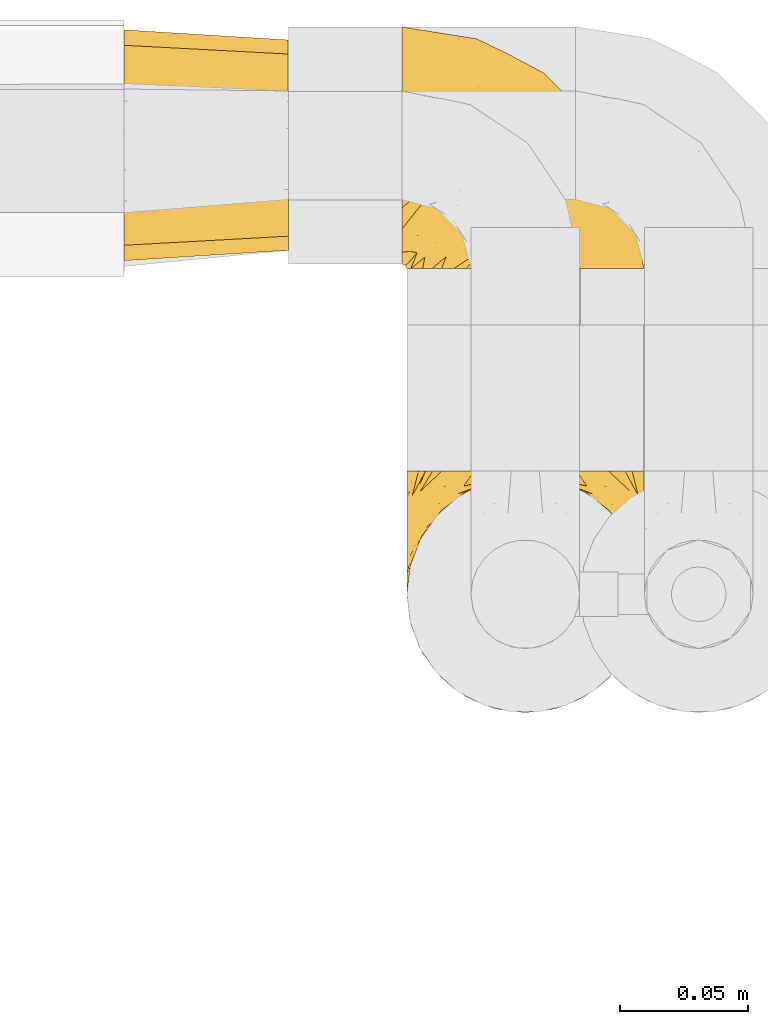
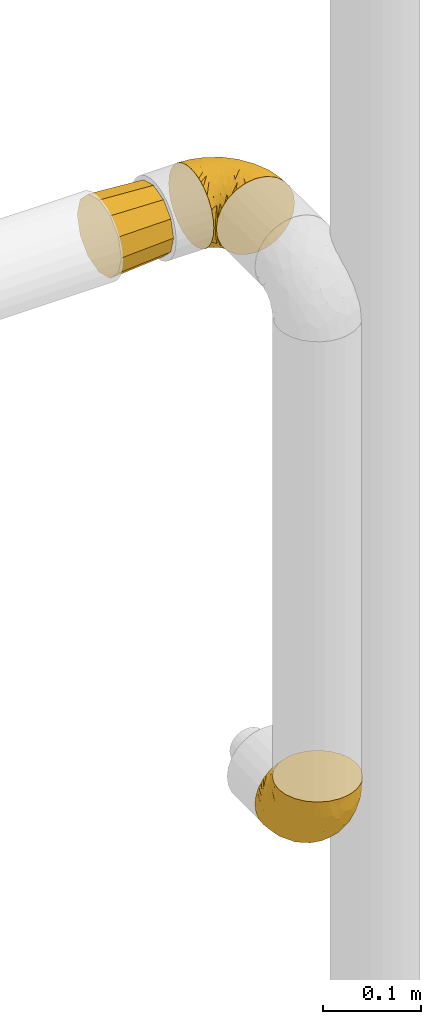
# One storey, part 317 of 827: 3 coverings.
"""IFC2X3 building model written with IfcOpenShell, lengths in millimetres."""

from ifc_helpers import new_model, entity, si_unit, converted_unit, derived_unit, direction, frame, origin, place, context, subcontext, project, spatial, faceted_brep, element, save


model = new_model("IFC2X3")

# Units and contexts
model_context = context("Model", 3, precision=0.01, world=origin(), true_north=direction((6.12303176911189e-17, 1.0)))
body_context = subcontext(model_context, "Body", "Model", "MODEL_VIEW")
ifc_project = project(units=[si_unit("LENGTHUNIT", "METRE", prefix="MILLI"), si_unit("AREAUNIT", "SQUARE_METRE"), si_unit("VOLUMEUNIT", "CUBIC_METRE"), converted_unit("PLANEANGLEUNIT", "DEGREE", entity("IfcRatioMeasure", 0.0174532925199433), si_unit("PLANEANGLEUNIT", "RADIAN"), dimensions=[0, 0, 0, 0, 0, 0, 0]), si_unit("MASSUNIT", "GRAM", prefix="KILO"), derived_unit("MASSDENSITYUNIT", [(si_unit("MASSUNIT", "GRAM", prefix="KILO"), 1), (si_unit("LENGTHUNIT", "METRE"), -3)]), derived_unit("MOMENTOFINERTIAUNIT", [(si_unit("LENGTHUNIT", "METRE"), 4)]), si_unit("TIMEUNIT", "SECOND"), si_unit("FREQUENCYUNIT", "HERTZ"), si_unit("THERMODYNAMICTEMPERATUREUNIT", "DEGREE_CELSIUS"), derived_unit("THERMALTRANSMITTANCEUNIT", [(si_unit("MASSUNIT", "GRAM", prefix="KILO"), 1), (si_unit("THERMODYNAMICTEMPERATUREUNIT", "KELVIN"), -1), (si_unit("TIMEUNIT", "SECOND"), -3)]), derived_unit("VOLUMETRICFLOWRATEUNIT", [(si_unit("LENGTHUNIT", "METRE"), 3), (si_unit("TIMEUNIT", "SECOND"), -1)]), derived_unit("MASSFLOWRATEUNIT", [(si_unit("MASSUNIT", "GRAM", prefix="KILO"), 1), (si_unit("TIMEUNIT", "SECOND"), -1)]), derived_unit("ROTATIONALFREQUENCYUNIT", [(si_unit("TIMEUNIT", "SECOND"), -1)]), si_unit("ELECTRICCURRENTUNIT", "AMPERE"), si_unit("ELECTRICVOLTAGEUNIT", "VOLT"), si_unit("POWERUNIT", "WATT"), si_unit("FORCEUNIT", "NEWTON", prefix="KILO"), si_unit("ILLUMINANCEUNIT", "LUX"), si_unit("LUMINOUSFLUXUNIT", "LUMEN"), si_unit("LUMINOUSINTENSITYUNIT", "CANDELA"), derived_unit("USERDEFINED", [(si_unit("MASSUNIT", "GRAM", prefix="KILO"), -1), (si_unit("LENGTHUNIT", "METRE"), -2), (si_unit("TIMEUNIT", "SECOND"), 3), (si_unit("LUMINOUSFLUXUNIT", "LUMEN"), 1)]), derived_unit("LINEARVELOCITYUNIT", [(si_unit("LENGTHUNIT", "METRE"), 1), (si_unit("TIMEUNIT", "SECOND"), -1)]), si_unit("PRESSUREUNIT", "PASCAL"), derived_unit("USERDEFINED", [(si_unit("LENGTHUNIT", "METRE"), -2), (si_unit("MASSUNIT", "GRAM", prefix="KILO"), 1), (si_unit("TIMEUNIT", "SECOND"), -2)]), derived_unit("LINEARFORCEUNIT", [(si_unit("MASSUNIT", "GRAM", prefix="KILO"), 1), (si_unit("LENGTHUNIT", "METRE"), 1), (si_unit("TIMEUNIT", "SECOND"), -2), (si_unit("LENGTHUNIT", "METRE"), -1)]), derived_unit("PLANARFORCEUNIT", [(si_unit("MASSUNIT", "GRAM", prefix="KILO"), 1), (si_unit("LENGTHUNIT", "METRE"), 1), (si_unit("TIMEUNIT", "SECOND"), -2), (si_unit("LENGTHUNIT", "METRE"), -2)])], contexts=[model_context])

# Site, building, storey
site_placement = place(None, origin())
site = spatial("IfcSite", under=ifc_project, at=site_placement, CompositionType="ELEMENT")
building_placement = place(site_placement, origin())
building = spatial("IfcBuilding", under=site, at=building_placement, CompositionType="ELEMENT")
storey_placement = place(building_placement, frame((0.0, 0.0, 28200.0)))
storey = spatial("IfcBuildingStorey", under=building, at=storey_placement, Name="08", CompositionType="ELEMENT", Elevation=28200.0)

# Coverings
covering_1_placement = place(storey_placement, frame((30526.79, 19295.64, 1082.65)))
element("IfcCovering", 1, at=covering_1_placement, inside=storey, Name=":ADSK_", ObjectType=":ADSK_", PredefinedType="INSULATION", context=body_context, shape_type="Brep", body=[
    faceted_brep([(83.91, 95.8, 18.98), (76.59, 95.8, 11.67), (67.83, 95.8, 6.17), (58.07, 95.8, 2.75), (47.8, 95.8, 1.6), (37.51, 95.8, 2.75), (27.74, 95.8, 6.17), (18.98, 95.8, 11.68), (11.67, 95.8, 19.0), (6.17, 95.8, 27.76), (2.75, 95.8, 37.52), (1.6, 95.8, 47.8), (2.06, 95.8, 51.94), (2.41, 95.8, 55.01), (2.75, 95.8, 58.08), (4.46, 95.8, 62.96), (6.17, 95.8, 67.85), (8.93, 95.8, 72.23), (11.68, 95.8, 76.61), (15.34, 95.8, 80.26), (19.0, 95.8, 83.92), (27.76, 95.8, 89.42), (32.64, 95.8, 91.13), (37.52, 95.8, 92.84), (47.8, 95.8, 94.0), (58.08, 95.8, 92.84), (62.96, 95.8, 91.13), (67.85, 95.8, 89.42), (76.61, 95.8, 83.91), (80.26, 95.8, 80.25), (83.92, 95.8, 76.59), (86.67, 95.8, 72.21), (89.42, 95.8, 67.83), (91.13, 95.8, 62.95), (92.84, 95.8, 58.07), (93.18, 95.8, 55.0), (93.53, 95.8, 51.94), (94.0, 95.8, 47.8), (92.84, 95.8, 37.51), (89.42, 95.8, 27.74), (47.8, 94.0, 95.8), (35.84, 92.42, 95.8), (24.7, 87.81, 95.8), (19.91, 84.13, 95.8), (15.13, 80.46, 95.8), (11.46, 75.68, 95.8), (7.78, 70.9, 95.8), (5.48, 65.32, 95.8), (3.17, 59.75, 95.8), (2.69, 56.14, 95.8), (2.42, 54.06, 95.8), (2.14, 51.97, 95.8), (1.6, 47.8, 95.8), (3.17, 35.84, 95.8), (7.78, 24.7, 95.8), (15.13, 15.13, 95.8), (24.7, 7.78, 95.8), (35.84, 3.17, 95.8), (47.8, 1.6, 95.8), (59.75, 3.17, 95.8), (70.9, 7.78, 95.8), (80.46, 15.13, 95.8), (87.81, 24.7, 95.8), (92.42, 35.84, 95.8), (94.0, 47.8, 95.8), (93.45, 51.97, 95.8), (92.9, 56.14, 95.8), (92.42, 59.75, 95.8), (90.11, 65.32, 95.8), (87.81, 70.9, 95.8), (84.13, 75.68, 95.8), (80.46, 80.46, 95.8), (75.68, 84.13, 95.8), (70.9, 87.81, 95.8), (59.75, 92.42, 95.8), (71.98, 15.84, 60.58), (63.6, 6.99, 74.11), (59.72, 14.39, 51.59), (47.8, 6.21, 66.69), (55.16, 4.26, 76.19), (47.8, 3.39, 84.43), (63.76, 31.2, 31.2), (72.22, 26.47, 42.88), (74.18, 11.44, 79.41), (92.52, 47.66, 60.7), (94.0, 61.85, 61.85), (94.0, 59.25, 65.75), (94.0, 56.65, 69.64), (94.0, 54.05, 73.53), (94.0, 51.45, 77.43), (82.14, 19.8, 74.59), (80.34, 26.22, 54.72), (87.52, 31.58, 64.18), (79.59, 38.36, 37.94), (78.25, 51.54, 25.89), (85.01, 51.6, 34.73), (90.25, 55.97, 42.89), (93.2, 62.88, 49.83), (87.23, 41.35, 48.58), (85.55, 82.24, 22.41), (93.0, 40.88, 78.69), (89.31, 29.0, 81.64), (61.31, 74.06, 6.22), (56.86, 54.53, 12.11), (68.34, 57.98, 14.81), (65.71, 43.81, 21.61), (56.99, 38.22, 22.41), (72.15, 38.33, 30.12), (70.34, 74.76, 10.01), (78.36, 76.85, 15.36), (47.8, 84.43, 3.39), (47.8, 40.43, 19.59), (47.8, 30.01, 30.01), (93.06, 78.67, 41.19), (94.0, 92.06, 48.54), (94.0, 88.32, 49.28), (94.0, 85.6, 49.82), (94.0, 82.88, 50.37), (94.0, 80.15, 50.91), (94.0, 77.43, 51.45), (89.88, 76.36, 31.61), (94.0, 50.91, 80.15), (94.0, 50.37, 82.88), (94.0, 49.82, 85.6), (94.0, 49.28, 88.32), (94.0, 48.91, 90.19), (94.0, 48.54, 92.06), (47.8, 66.69, 6.21), (94.0, 73.53, 54.05), (94.0, 69.64, 56.65), (94.0, 65.75, 59.25), (83.7, 66.13, 24.66), (47.8, 19.59, 40.43), (55.9, 24.64, 35.17), (47.8, 53.56, 12.9), (47.8, 12.9, 53.56), (81.75, 82.81, 85.34), (86.43, 81.22, 78.44), (79.8, 86.57, 84.37), (69.84, 92.75, 89.05), (79.5, 89.68, 82.76), (88.08, 72.26, 86.31), (91.6, 64.73, 83.73), (92.93, 62.45, 77.31), (92.43, 60.63, 87.78), (93.24, 56.91, 87.91), (93.36, 58.14, 81.29), (57.25, 93.7, 93.97), (89.41, 83.4, 70.76), (92.89, 75.54, 63.67), (92.66, 79.46, 62.62), (79.58, 82.28, 90.64), (86.51, 76.25, 84.08), (83.91, 90.18, 77.45), (88.76, 87.92, 70.34), (90.94, 65.12, 88.72), (91.94, 71.71, 71.28), (91.98, 75.21, 68.09), (82.79, 78.6, 91.07), (93.16, 87.27, 57.47), (73.94, 86.94, 91.35), (91.89, 86.1, 62.99), (47.8, 94.52, 94.52), (92.22, 66.23, 76.47), (86.29, 84.69, 76.28), (88.56, 91.08, 69.96), (87.72, 71.77, 89.86), (88.33, 76.21, 78.94), (92.18, 68.59, 73.51), (71.78, 89.94, 89.62), (9.09, 76.25, 84.09), (7.51, 72.26, 86.3), (12.8, 78.6, 91.06), (1.6, 48.54, 92.06), (1.6, 50.37, 82.88), (1.6, 49.82, 85.6), (1.6, 49.28, 88.32), (38.35, 93.7, 93.97), (23.84, 89.95, 89.63), (1.6, 82.88, 50.37), (1.6, 85.6, 49.82), (1.6, 92.06, 48.54), (1.6, 88.32, 49.28), (16.1, 89.68, 82.77), (6.84, 87.92, 70.36), (2.66, 62.45, 77.31), (3.37, 66.24, 76.47), (1.6, 56.65, 69.64), (1.6, 59.25, 65.75), (3.16, 60.63, 87.78), (2.35, 56.91, 87.91), (25.77, 92.76, 89.06), (16.02, 82.28, 90.65), (13.85, 82.81, 85.35), (1.6, 54.05, 73.53), (1.6, 51.45, 77.43), (2.23, 58.14, 81.29), (11.69, 90.18, 77.46), (9.31, 84.7, 76.29), (2.43, 87.25, 57.47), (2.71, 75.58, 63.71), (3.61, 75.2, 68.11), (6.18, 83.39, 70.77), (3.66, 71.7, 71.31), (9.17, 81.22, 78.46), (6.77, 90.73, 69.52), (2.93, 79.47, 62.64), (21.66, 86.94, 91.35), (1.6, 65.75, 59.25), (16.09, 86.75, 84.6), (3.7, 86.08, 62.98), (1.6, 77.43, 51.45), (1.6, 73.53, 54.05), (1.6, 69.64, 56.65), (3.99, 64.73, 83.73), (1.6, 50.91, 80.15), (4.65, 65.12, 88.72), (1.6, 61.85, 61.85), (3.43, 68.62, 73.56), (7.27, 76.22, 78.96), (9.46, 74.03, 91.36), (1.6, 80.15, 50.91), (2.4, 49.81, 62.87), (40.43, 4.26, 76.19), (13.57, 19.95, 73.57), (11.3, 30.61, 56.07), (18.65, 25.71, 49.77), (27.26, 22.43, 44.73), (23.61, 15.85, 60.58), (3.07, 60.69, 47.64), (2.69, 40.49, 78.32), (35.87, 14.39, 51.59), (31.99, 6.99, 74.11), (6.71, 29.56, 76.04), (21.41, 11.45, 79.41), (27.24, 57.98, 14.82), (34.26, 74.06, 6.22), (38.73, 54.52, 12.12), (26.97, 43.47, 23.51), (31.83, 31.2, 31.2), (23.4, 33.27, 34.96), (6.91, 64.26, 33.86), (3.4, 74.29, 38.94), (5.84, 80.41, 30.23), (35.73, 41.67, 20.67), (39.69, 24.64, 35.17), (17.6, 73.62, 15.85), (10.38, 78.98, 22.59), (20.6, 53.69, 21.56), (5.36, 42.86, 55.94), (24.84, 79.66, 9.19), (13.87, 58.41, 25.79), (9.06, 47.11, 41.16), (15.99, 38.37, 37.95)], [[[0, 1, 2, 3, 4, 5, 6, 7, 8, 9, 10, 11, 12, 13, 14, 15, 16, 17, 18, 19, 20, 21, 22, 23, 24, 25, 26, 27, 28, 29, 30, 31, 32, 33, 34, 35, 36, 37, 38, 39]], [[40, 41, 42, 43, 44, 45, 46, 47, 48, 49, 50, 51, 52, 53, 54, 55, 56, 57, 58, 59, 60, 61, 62, 63, 64, 65, 66, 67, 68, 69, 70, 71, 72, 73, 74]], [[75, 76, 77]], [[78, 79, 80]], [[77, 81, 82]], [[76, 75, 83]], [[84, 85, 86, 87, 88, 89]], [[90, 91, 92]], [[76, 60, 59]], [[93, 94, 95]], [[90, 62, 61]], [[83, 61, 60]], [[96, 97, 84]], [[98, 93, 95]], [[0, 39, 99]], [[100, 84, 89]], [[62, 101, 63]], [[2, 102, 3]], [[92, 84, 100]], [[103, 102, 104]], [[103, 105, 106]], [[93, 107, 94]], [[1, 108, 2]], [[92, 101, 90]], [[108, 1, 109]], [[102, 110, 3]], [[93, 82, 107]], [[102, 108, 104]], [[111, 106, 112]], [[109, 0, 99]], [[113, 37, 114, 115, 116, 117, 118, 119]], [[120, 38, 113]], [[100, 89, 121, 122, 123, 124, 125, 126, 64]], [[127, 102, 103]], [[97, 119, 128, 129, 130, 85]], [[99, 120, 131]], [[132, 133, 77]], [[59, 80, 79]], [[1, 0, 109]], [[98, 84, 92]], [[94, 109, 131]], [[120, 39, 38]], [[93, 91, 82]], [[104, 94, 105]], [[97, 113, 119]], [[95, 120, 96]], [[83, 90, 61]], [[91, 93, 98]], [[64, 63, 100]], [[100, 63, 101]], [[77, 76, 79]], [[133, 106, 81]], [[84, 97, 85]], [[113, 96, 120]], [[113, 97, 96]], [[37, 113, 38]], [[110, 102, 127]], [[110, 4, 3]], [[103, 111, 134, 127]], [[90, 75, 91]], [[82, 81, 107]], [[91, 75, 82]], [[77, 82, 75]], [[76, 83, 60]], [[90, 83, 75]], [[105, 107, 81]], [[94, 131, 95]], [[105, 94, 107]], [[109, 94, 104]], [[120, 95, 131]], [[98, 95, 96]], [[84, 98, 96]], [[98, 92, 91]], [[106, 105, 81]], [[103, 104, 105]], [[133, 132, 112]], [[103, 106, 111]], [[77, 78, 135, 132]], [[81, 77, 133]], [[106, 133, 112]], [[120, 99, 39]], [[109, 99, 131]], [[59, 58, 80]], [[59, 79, 76]], [[90, 101, 62]], [[100, 101, 92]], [[2, 108, 102]], [[109, 104, 108]], [[78, 77, 79]], [[136, 137, 138]], [[27, 139, 140]], [[141, 142, 143]], [[144, 145, 121]], [[146, 89, 88]], [[147, 139, 25]], [[148, 149, 150]], [[136, 151, 152]], [[147, 40, 74]], [[24, 147, 25]], [[153, 148, 154]], [[33, 116, 34]], [[73, 72, 151]], [[114, 37, 36, 35, 34, 116, 115]], [[146, 155, 144]], [[156, 85, 130]], [[157, 149, 148]], [[151, 158, 152]], [[117, 33, 159]], [[29, 153, 154]], [[160, 74, 73]], [[161, 128, 119]], [[66, 65, 64, 126, 125, 124, 123, 122, 67]], [[162, 147, 24]], [[27, 140, 28]], [[149, 129, 150]], [[139, 27, 26, 25]], [[68, 144, 69]], [[129, 128, 150]], [[163, 87, 86]], [[130, 129, 149]], [[122, 145, 67]], [[153, 164, 148]], [[161, 119, 159]], [[165, 30, 154]], [[150, 154, 148]], [[128, 161, 150]], [[30, 165, 31]], [[145, 144, 68]], [[89, 146, 144]], [[87, 163, 143]], [[166, 155, 142]], [[88, 87, 143]], [[161, 154, 150]], [[154, 30, 29]], [[29, 28, 153]], [[28, 140, 153]], [[164, 153, 140]], [[140, 137, 164]], [[157, 148, 164]], [[156, 130, 157]], [[164, 137, 157]], [[157, 137, 156]], [[167, 137, 136]], [[168, 85, 156]], [[152, 168, 167]], [[167, 168, 156]], [[163, 152, 141]], [[71, 158, 72]], [[152, 167, 136]], [[88, 142, 146]], [[144, 155, 69]], [[146, 142, 155]], [[70, 166, 71]], [[142, 141, 166]], [[70, 69, 155]], [[141, 158, 71]], [[160, 73, 151]], [[138, 137, 140]], [[160, 136, 169]], [[136, 160, 151]], [[74, 160, 169]], [[152, 158, 141]], [[151, 72, 158]], [[168, 152, 163]], [[137, 167, 156]], [[163, 86, 168]], [[85, 168, 86]], [[116, 33, 117]], [[130, 149, 157]], [[67, 145, 68]], [[121, 89, 144]], [[145, 122, 121]], [[40, 147, 162]], [[169, 147, 74]], [[159, 33, 32]], [[161, 159, 32]], [[159, 119, 118, 117]], [[139, 147, 169]], [[139, 169, 138]], [[161, 32, 31]], [[141, 143, 163]], [[88, 143, 142]], [[71, 166, 141]], [[155, 166, 70]], [[139, 138, 140]], [[169, 136, 138]], [[154, 161, 165]], [[161, 31, 165]], [[170, 171, 172]], [[173, 52, 51, 50, 49, 48, 174, 175, 176]], [[177, 178, 41]], [[179, 15, 180]], [[12, 11, 181, 182, 180, 14, 13]], [[183, 21, 20]], [[19, 18, 184]], [[185, 186, 187]], [[186, 188, 187]], [[43, 172, 44]], [[189, 190, 47]], [[23, 22, 21, 191]], [[170, 192, 193]], [[40, 162, 177]], [[194, 195, 196]], [[24, 23, 177]], [[197, 198, 183]], [[199, 15, 179]], [[47, 46, 189]], [[200, 201, 202]], [[201, 203, 204]], [[205, 206, 184]], [[207, 41, 178]], [[16, 15, 199]], [[14, 180, 15]], [[202, 201, 198]], [[208, 201, 200]], [[162, 24, 177]], [[48, 47, 190]], [[196, 195, 189]], [[197, 184, 202]], [[204, 193, 209]], [[210, 211, 212]], [[206, 212, 213]], [[205, 17, 210]], [[184, 206, 202]], [[210, 212, 206]], [[185, 194, 214]], [[189, 215, 190]], [[216, 45, 214]], [[186, 171, 170]], [[189, 216, 196]], [[197, 20, 19]], [[194, 185, 187]], [[197, 183, 20]], [[184, 197, 19]], [[197, 202, 198]], [[206, 200, 202]], [[204, 183, 198]], [[201, 208, 203]], [[203, 208, 217]], [[204, 198, 201]], [[217, 188, 218]], [[193, 219, 170]], [[171, 186, 185]], [[170, 218, 186]], [[170, 219, 218]], [[42, 207, 192]], [[171, 220, 172]], [[216, 189, 46]], [[214, 194, 196]], [[44, 220, 45]], [[214, 196, 216]], [[216, 46, 45]], [[214, 45, 220]], [[192, 43, 42]], [[204, 203, 219]], [[207, 193, 192]], [[209, 193, 178]], [[41, 207, 42]], [[193, 207, 178]], [[43, 192, 172]], [[170, 172, 192]], [[204, 219, 193]], [[219, 203, 218]], [[217, 218, 203]], [[188, 186, 218]], [[206, 213, 200]], [[208, 200, 213]], [[199, 210, 16]], [[215, 189, 195]], [[215, 174, 190]], [[174, 48, 190]], [[199, 179, 221, 211]], [[210, 199, 211]], [[23, 191, 177]], [[40, 177, 41]], [[183, 209, 191]], [[183, 191, 21]], [[191, 178, 177]], [[205, 18, 17]], [[17, 16, 210]], [[171, 185, 214]], [[172, 220, 44]], [[214, 220, 171]], [[191, 209, 178]], [[204, 209, 183]], [[206, 205, 210]], [[18, 205, 184]], [[222, 195, 194, 187, 188, 217]], [[57, 223, 80]], [[224, 225, 226]], [[226, 227, 228]], [[229, 217, 208, 213, 212, 211]], [[230, 52, 173, 176, 175, 174, 215, 195]], [[231, 232, 228]], [[231, 78, 223]], [[223, 57, 232]], [[224, 233, 225]], [[233, 54, 53]], [[234, 232, 56]], [[56, 55, 234]], [[234, 224, 228]], [[235, 236, 237]], [[224, 55, 54]], [[238, 239, 240]], [[52, 230, 53]], [[241, 242, 243]], [[239, 244, 245]], [[11, 10, 242]], [[236, 6, 5]], [[7, 246, 8]], [[8, 247, 9]], [[238, 248, 235]], [[222, 229, 249]], [[242, 211, 221, 179, 180, 182, 181, 11]], [[233, 53, 230]], [[111, 112, 244]], [[250, 6, 236]], [[247, 251, 241]], [[6, 250, 7]], [[127, 236, 110]], [[249, 229, 252]], [[247, 8, 246]], [[235, 246, 250]], [[236, 5, 110]], [[235, 244, 238]], [[237, 236, 127]], [[243, 9, 247]], [[252, 229, 241]], [[56, 232, 57]], [[222, 230, 195]], [[225, 249, 252]], [[249, 233, 230]], [[54, 233, 224]], [[231, 228, 227]], [[245, 132, 231]], [[249, 225, 233]], [[226, 225, 253]], [[235, 250, 236]], [[246, 7, 250]], [[251, 247, 246]], [[243, 247, 241]], [[248, 246, 235]], [[252, 251, 253]], [[229, 222, 217]], [[230, 222, 249]], [[5, 4, 110]], [[237, 127, 134, 111]], [[238, 244, 239]], [[224, 234, 55]], [[232, 234, 228]], [[242, 241, 229]], [[10, 9, 243]], [[211, 242, 229]], [[10, 243, 242]], [[80, 223, 78]], [[80, 58, 57]], [[231, 223, 232]], [[227, 240, 239]], [[224, 226, 228]], [[240, 226, 253]], [[227, 239, 245]], [[226, 240, 227]], [[251, 248, 253]], [[240, 253, 248]], [[244, 235, 237]], [[237, 111, 244]], [[132, 245, 112]], [[112, 245, 244]], [[135, 78, 231, 132]], [[227, 245, 231]], [[248, 238, 240]], [[246, 248, 251]], [[251, 252, 241]], [[225, 252, 253]]]),
])
covering_2_placement = place(storey_placement, frame((30524.99, 19468.74, 1752.2)))
element("IfcCovering", 2, at=covering_2_placement, inside=storey, Name=":ADSK_", ObjectType=":ADSK_", PredefinedType="INSULATION", context=body_context, shape_type="Brep", body=[
    faceted_brep([(1.6, 78.41, 83.91), (1.6, 85.72, 76.59), (1.6, 91.22, 67.83), (1.6, 94.64, 58.07), (1.6, 95.8, 47.8), (1.6, 94.64, 37.51), (1.6, 91.22, 27.74), (1.6, 85.71, 18.98), (1.6, 78.39, 11.67), (1.6, 69.63, 6.17), (1.6, 59.87, 2.75), (1.6, 49.6, 1.6), (1.6, 45.45, 2.06), (1.6, 42.38, 2.41), (1.6, 39.31, 2.75), (1.6, 34.43, 4.46), (1.6, 29.54, 6.17), (1.6, 25.16, 8.93), (1.6, 20.78, 11.68), (1.6, 17.13, 15.34), (1.6, 13.47, 19.0), (1.6, 7.97, 27.76), (1.6, 6.26, 32.64), (1.6, 4.55, 37.52), (1.6, 3.4, 47.8), (1.6, 4.55, 58.08), (1.6, 6.26, 62.96), (1.6, 7.97, 67.85), (1.6, 13.48, 76.61), (1.6, 17.14, 80.26), (1.6, 20.8, 83.92), (1.6, 25.18, 86.67), (1.6, 29.56, 89.42), (1.6, 34.44, 91.13), (1.6, 39.32, 92.84), (1.6, 42.39, 93.18), (1.6, 45.45, 93.53), (1.6, 49.6, 94.0), (1.6, 59.88, 92.84), (1.6, 69.65, 89.42), (3.4, 1.6, 47.8), (4.97, 1.6, 35.84), (9.58, 1.6, 24.7), (13.26, 1.6, 19.91), (16.93, 1.6, 15.13), (21.71, 1.6, 11.46), (26.5, 1.6, 7.78), (32.07, 1.6, 5.48), (37.64, 1.6, 3.17), (41.25, 1.6, 2.69), (43.34, 1.6, 2.42), (45.42, 1.6, 2.14), (49.6, 1.6, 1.6), (61.55, 1.6, 3.17), (72.7, 1.6, 7.78), (82.26, 1.6, 15.13), (89.61, 1.6, 24.7), (94.22, 1.6, 35.84), (95.8, 1.6, 47.8), (94.22, 1.6, 59.75), (89.61, 1.6, 70.9), (82.26, 1.6, 80.46), (72.7, 1.6, 87.81), (61.55, 1.6, 92.42), (49.6, 1.6, 94.0), (45.42, 1.6, 93.45), (41.25, 1.6, 92.9), (37.64, 1.6, 92.42), (32.07, 1.6, 90.11), (26.5, 1.6, 87.81), (21.71, 1.6, 84.13), (16.93, 1.6, 80.46), (13.26, 1.6, 75.68), (9.58, 1.6, 70.9), (4.97, 1.6, 59.75), (81.55, 36.81, 71.98), (90.4, 23.28, 63.6), (83.0, 45.8, 59.72), (91.18, 30.7, 47.8), (93.13, 21.2, 55.16), (94.0, 12.96, 47.8), (66.19, 66.19, 63.76), (70.92, 54.51, 72.22), (85.95, 17.98, 74.18), (49.74, 36.69, 92.52), (35.54, 35.54, 94.0), (38.14, 31.64, 94.0), (40.74, 27.75, 94.0), (43.34, 23.86, 94.0), (45.94, 19.96, 94.0), (77.59, 22.8, 82.14), (71.17, 42.67, 80.34), (65.81, 33.21, 87.52), (59.03, 59.45, 79.59), (45.85, 71.5, 78.25), (45.79, 62.66, 85.01), (41.42, 54.5, 90.25), (34.51, 47.57, 93.2), (56.04, 48.81, 87.23), (15.15, 74.98, 85.55), (56.51, 18.7, 93.0), (68.39, 15.75, 89.31), (23.33, 91.17, 61.31), (42.86, 85.28, 56.86), (39.42, 82.58, 68.34), (53.58, 75.78, 65.71), (59.17, 74.98, 56.99), (59.06, 67.27, 72.15), (22.63, 87.38, 70.34), (20.55, 82.04, 78.36), (12.96, 94.0, 47.8), (56.96, 77.8, 47.8), (67.38, 67.38, 47.8), (18.72, 56.2, 93.06), (5.33, 48.85, 94.0), (9.07, 48.11, 94.0), (11.79, 47.57, 94.0), (14.51, 47.03, 94.0), (17.24, 46.48, 94.0), (19.96, 45.94, 94.0), (21.03, 65.78, 89.88), (46.48, 17.24, 94.0), (47.03, 14.51, 94.0), (47.57, 11.79, 94.0), (48.11, 9.07, 94.0), (48.48, 7.2, 94.0), (48.85, 5.33, 94.0), (30.7, 91.18, 47.8), (23.86, 43.34, 94.0), (27.75, 40.74, 94.0), (31.64, 38.14, 94.0), (31.26, 72.73, 83.7), (77.8, 56.96, 47.8), (72.75, 62.23, 55.9), (43.83, 84.49, 47.8), (84.49, 43.83, 47.8), (14.58, 12.05, 81.75), (16.17, 18.95, 86.43), (10.82, 13.02, 79.8), (4.64, 8.34, 69.84), (7.71, 14.63, 79.5), (25.13, 11.09, 88.08), (32.66, 13.66, 91.6), (34.94, 20.08, 92.93), (36.76, 9.61, 92.43), (40.48, 9.48, 93.24), (39.25, 16.1, 93.36), (3.69, 3.42, 57.25), (13.99, 26.63, 89.41), (21.85, 33.72, 92.89), (17.93, 34.77, 92.66), (15.11, 6.75, 79.58), (21.14, 13.31, 86.51), (7.21, 19.94, 83.91), (9.47, 27.05, 88.76), (32.27, 8.67, 90.94), (25.68, 26.11, 91.94), (22.18, 29.3, 91.98), (18.79, 6.32, 82.79), (10.12, 39.92, 93.16), (10.45, 6.04, 73.94), (11.29, 34.4, 91.89), (2.87, 2.87, 47.8), (31.16, 20.92, 92.22), (12.7, 21.11, 86.29), (6.31, 27.43, 88.56), (25.62, 7.54, 87.72), (21.18, 18.45, 88.33), (28.81, 23.88, 92.18), (7.45, 7.77, 71.78), (21.14, 13.3, 9.09), (25.13, 11.09, 7.51), (18.79, 6.33, 12.8), (48.11, 9.07, 1.6), (48.85, 5.33, 1.6), (47.03, 14.51, 1.6), (47.57, 11.79, 1.6), (3.69, 3.42, 38.35), (7.44, 7.76, 23.84), (14.51, 47.03, 1.6), (11.79, 47.57, 1.6), (5.33, 48.85, 1.6), (9.07, 48.11, 1.6), (7.71, 14.62, 16.1), (9.47, 27.03, 6.84), (34.94, 20.08, 2.66), (31.16, 20.92, 3.37), (40.74, 27.75, 1.6), (38.14, 31.64, 1.6), (36.76, 9.61, 3.16), (40.48, 9.48, 2.35), (4.63, 8.33, 25.77), (15.11, 6.74, 16.02), (14.58, 12.04, 13.85), (43.34, 23.86, 1.6), (45.94, 19.96, 1.6), (39.25, 16.1, 2.23), (7.21, 19.93, 11.69), (12.69, 21.1, 9.31), (10.14, 39.92, 2.43), (21.81, 33.68, 2.71), (22.19, 29.28, 3.61), (14.0, 26.62, 6.18), (25.69, 26.08, 3.66), (16.17, 18.93, 9.17), (6.66, 27.87, 6.77), (17.92, 34.75, 2.93), (10.45, 6.04, 21.66), (31.64, 38.14, 1.6), (10.64, 12.79, 16.09), (11.31, 34.41, 3.7), (19.96, 45.94, 1.6), (23.86, 43.34, 1.6), (27.75, 40.74, 1.6), (32.66, 13.66, 3.99), (46.48, 17.24, 1.6), (32.27, 8.67, 4.65), (35.54, 35.54, 1.6), (28.77, 23.83, 3.43), (21.17, 18.43, 7.27), (23.36, 6.03, 9.46), (17.24, 46.48, 1.6), (47.58, 34.52, 2.4), (93.13, 21.2, 40.43), (77.44, 23.82, 13.57), (66.78, 41.32, 11.3), (71.68, 47.62, 18.65), (74.96, 52.66, 27.26), (81.55, 36.81, 23.61), (36.7, 49.75, 3.07), (56.9, 19.07, 2.69), (83.0, 45.8, 35.87), (90.4, 23.28, 31.99), (67.83, 21.35, 6.71), (85.95, 17.98, 21.41), (39.41, 82.57, 27.24), (23.33, 91.17, 34.26), (42.87, 85.27, 38.73), (53.92, 73.89, 26.97), (66.19, 66.19, 31.83), (64.12, 62.43, 23.4), (33.13, 63.53, 6.91), (23.1, 58.45, 3.4), (16.98, 67.16, 5.84), (72.75, 62.22, 39.69), (23.77, 81.54, 17.6), (18.41, 74.8, 10.38), (43.7, 75.83, 20.6), (54.53, 41.45, 5.36), (55.72, 76.72, 35.73), (17.73, 88.2, 24.84), (38.98, 71.6, 13.87), (50.28, 56.23, 9.06), (59.02, 59.44, 15.99)], [[[0, 1, 2, 3, 4, 5, 6, 7, 8, 9, 10, 11, 12, 13, 14, 15, 16, 17, 18, 19, 20, 21, 22, 23, 24, 25, 26, 27, 28, 29, 30, 31, 32, 33, 34, 35, 36, 37, 38, 39]], [[40, 41, 42, 43, 44, 45, 46, 47, 48, 49, 50, 51, 52, 53, 54, 55, 56, 57, 58, 59, 60, 61, 62, 63, 64, 65, 66, 67, 68, 69, 70, 71, 72, 73, 74]], [[75, 76, 77]], [[78, 79, 80]], [[77, 81, 82]], [[76, 75, 83]], [[84, 85, 86, 87, 88, 89]], [[90, 91, 92]], [[76, 60, 59]], [[93, 94, 95]], [[90, 62, 61]], [[83, 61, 60]], [[96, 97, 84]], [[98, 93, 95]], [[0, 39, 99]], [[100, 84, 89]], [[62, 101, 63]], [[2, 102, 3]], [[92, 84, 100]], [[103, 102, 104]], [[103, 105, 106]], [[93, 107, 94]], [[1, 108, 2]], [[92, 101, 90]], [[108, 1, 109]], [[102, 110, 3]], [[93, 82, 107]], [[102, 108, 104]], [[111, 106, 112]], [[109, 0, 99]], [[113, 37, 114, 115, 116, 117, 118, 119]], [[120, 38, 113]], [[100, 89, 121, 122, 123, 124, 125, 126, 64]], [[127, 102, 103]], [[97, 119, 128, 129, 130, 85]], [[99, 120, 131]], [[132, 133, 77]], [[59, 80, 79]], [[1, 0, 109]], [[98, 84, 92]], [[94, 109, 131]], [[120, 39, 38]], [[93, 91, 82]], [[104, 94, 105]], [[97, 113, 119]], [[95, 120, 96]], [[83, 90, 61]], [[91, 93, 98]], [[64, 63, 100]], [[100, 63, 101]], [[77, 76, 79]], [[133, 106, 81]], [[84, 97, 85]], [[113, 96, 120]], [[113, 97, 96]], [[37, 113, 38]], [[110, 102, 127]], [[110, 4, 3]], [[103, 111, 134, 127]], [[90, 75, 91]], [[82, 81, 107]], [[91, 75, 82]], [[77, 82, 75]], [[76, 83, 60]], [[90, 83, 75]], [[105, 107, 81]], [[94, 131, 95]], [[105, 94, 107]], [[109, 94, 104]], [[120, 95, 131]], [[98, 95, 96]], [[84, 98, 96]], [[98, 92, 91]], [[106, 105, 81]], [[103, 104, 105]], [[133, 132, 112]], [[103, 106, 111]], [[77, 78, 135, 132]], [[106, 133, 112]], [[77, 133, 81]], [[120, 99, 39]], [[109, 99, 131]], [[59, 58, 80]], [[59, 79, 76]], [[90, 101, 62]], [[100, 101, 92]], [[2, 108, 102]], [[109, 104, 108]], [[78, 77, 79]], [[136, 137, 138]], [[27, 139, 140]], [[141, 142, 143]], [[144, 145, 121]], [[146, 89, 88]], [[147, 139, 25]], [[148, 149, 150]], [[136, 151, 152]], [[147, 40, 74]], [[24, 147, 25]], [[153, 148, 154]], [[33, 116, 34]], [[73, 72, 151]], [[114, 37, 36, 35, 34, 116, 115]], [[146, 155, 144]], [[156, 85, 130]], [[157, 149, 148]], [[151, 158, 152]], [[117, 33, 159]], [[29, 153, 154]], [[160, 74, 73]], [[161, 128, 119]], [[65, 64, 126, 125, 124, 123, 122, 67, 66]], [[162, 147, 24]], [[27, 140, 28]], [[149, 129, 150]], [[139, 27, 26, 25]], [[68, 144, 69]], [[129, 128, 150]], [[163, 87, 86]], [[130, 129, 149]], [[122, 145, 67]], [[153, 164, 148]], [[161, 119, 159]], [[165, 30, 154]], [[150, 154, 148]], [[128, 161, 150]], [[30, 165, 31]], [[145, 144, 68]], [[89, 146, 144]], [[87, 163, 143]], [[166, 155, 142]], [[88, 87, 143]], [[161, 154, 150]], [[154, 30, 29]], [[29, 28, 153]], [[28, 140, 153]], [[164, 153, 140]], [[140, 137, 164]], [[157, 148, 164]], [[156, 130, 157]], [[164, 137, 157]], [[157, 137, 156]], [[167, 137, 136]], [[168, 85, 156]], [[152, 168, 167]], [[167, 168, 156]], [[163, 152, 141]], [[71, 158, 72]], [[152, 167, 136]], [[88, 142, 146]], [[144, 155, 69]], [[146, 142, 155]], [[70, 166, 71]], [[142, 141, 166]], [[70, 69, 155]], [[141, 158, 71]], [[160, 73, 151]], [[138, 137, 140]], [[160, 136, 169]], [[136, 160, 151]], [[74, 160, 169]], [[152, 158, 141]], [[151, 72, 158]], [[168, 152, 163]], [[137, 167, 156]], [[163, 86, 168]], [[85, 168, 86]], [[116, 33, 117]], [[130, 149, 157]], [[67, 145, 68]], [[121, 89, 144]], [[145, 122, 121]], [[40, 147, 162]], [[169, 147, 74]], [[159, 33, 32]], [[161, 159, 32]], [[159, 119, 118, 117]], [[139, 147, 169]], [[139, 169, 138]], [[161, 32, 31]], [[141, 143, 163]], [[88, 143, 142]], [[71, 166, 141]], [[155, 166, 70]], [[139, 138, 140]], [[169, 136, 138]], [[154, 161, 165]], [[161, 31, 165]], [[170, 171, 172]], [[173, 174, 52, 51, 50, 49, 48, 175, 176]], [[177, 178, 41]], [[179, 15, 180]], [[12, 11, 181, 182, 180, 14, 13]], [[183, 21, 20]], [[19, 18, 184]], [[185, 186, 187]], [[186, 188, 187]], [[43, 172, 44]], [[189, 190, 47]], [[23, 22, 21, 191]], [[170, 192, 193]], [[40, 162, 177]], [[194, 195, 196]], [[24, 23, 177]], [[197, 198, 183]], [[199, 15, 179]], [[47, 46, 189]], [[200, 201, 202]], [[201, 203, 204]], [[205, 206, 184]], [[207, 41, 178]], [[16, 15, 199]], [[14, 180, 15]], [[202, 201, 198]], [[208, 201, 200]], [[162, 24, 177]], [[48, 47, 190]], [[196, 195, 189]], [[197, 184, 202]], [[204, 193, 209]], [[210, 211, 212]], [[206, 212, 213]], [[205, 17, 210]], [[184, 206, 202]], [[210, 212, 206]], [[185, 194, 214]], [[189, 215, 190]], [[216, 45, 214]], [[186, 171, 170]], [[189, 216, 196]], [[197, 20, 19]], [[194, 185, 187]], [[197, 183, 20]], [[184, 197, 19]], [[197, 202, 198]], [[206, 200, 202]], [[204, 183, 198]], [[201, 208, 203]], [[203, 208, 217]], [[204, 198, 201]], [[217, 188, 218]], [[193, 219, 170]], [[171, 186, 185]], [[170, 218, 186]], [[170, 219, 218]], [[42, 207, 192]], [[171, 220, 172]], [[216, 189, 46]], [[214, 194, 196]], [[44, 220, 45]], [[214, 196, 216]], [[216, 46, 45]], [[214, 45, 220]], [[192, 43, 42]], [[204, 203, 219]], [[207, 193, 192]], [[209, 193, 178]], [[41, 207, 42]], [[193, 207, 178]], [[43, 192, 172]], [[170, 172, 192]], [[204, 219, 193]], [[219, 203, 218]], [[217, 218, 203]], [[188, 186, 218]], [[206, 213, 200]], [[208, 200, 213]], [[199, 210, 16]], [[215, 189, 195]], [[215, 175, 190]], [[175, 48, 190]], [[199, 179, 221, 211]], [[210, 199, 211]], [[23, 191, 177]], [[40, 177, 41]], [[183, 209, 191]], [[183, 191, 21]], [[191, 178, 177]], [[205, 18, 17]], [[17, 16, 210]], [[171, 185, 214]], [[172, 220, 44]], [[214, 220, 171]], [[191, 209, 178]], [[204, 209, 183]], [[206, 205, 210]], [[18, 205, 184]], [[222, 195, 194, 187, 188, 217]], [[57, 223, 80]], [[224, 225, 226]], [[226, 227, 228]], [[229, 217, 208, 213, 212, 211]], [[230, 52, 174, 173, 176, 175, 215, 195]], [[231, 232, 228]], [[231, 78, 223]], [[223, 57, 232]], [[224, 233, 225]], [[233, 54, 53]], [[234, 232, 56]], [[56, 55, 234]], [[234, 224, 228]], [[235, 236, 237]], [[224, 55, 54]], [[238, 239, 240]], [[52, 230, 53]], [[241, 242, 243]], [[231, 227, 244]], [[11, 10, 242]], [[236, 6, 5]], [[7, 245, 8]], [[8, 246, 9]], [[238, 247, 235]], [[222, 229, 248]], [[242, 211, 221, 179, 180, 182, 181, 11]], [[233, 53, 230]], [[111, 112, 249]], [[250, 6, 236]], [[246, 251, 241]], [[6, 250, 7]], [[127, 236, 110]], [[248, 229, 252]], [[246, 8, 245]], [[235, 245, 250]], [[236, 5, 110]], [[235, 249, 238]], [[237, 236, 127]], [[243, 9, 246]], [[252, 229, 241]], [[56, 232, 57]], [[222, 230, 195]], [[225, 248, 252]], [[248, 233, 230]], [[54, 233, 224]], [[231, 228, 227]], [[244, 132, 231]], [[248, 225, 233]], [[226, 225, 253]], [[235, 250, 236]], [[245, 7, 250]], [[251, 246, 245]], [[243, 246, 241]], [[247, 245, 235]], [[252, 251, 253]], [[229, 222, 217]], [[230, 222, 248]], [[5, 4, 110]], [[237, 127, 134, 111]], [[238, 249, 239]], [[224, 234, 55]], [[232, 234, 228]], [[242, 241, 229]], [[10, 9, 243]], [[211, 242, 229]], [[10, 243, 242]], [[80, 223, 78]], [[80, 58, 57]], [[231, 223, 232]], [[227, 240, 239]], [[224, 226, 228]], [[240, 226, 253]], [[227, 239, 244]], [[226, 240, 227]], [[251, 247, 253]], [[240, 253, 247]], [[249, 235, 237]], [[237, 111, 249]], [[244, 239, 249]], [[112, 244, 249]], [[135, 78, 231, 132]], [[112, 132, 244]], [[247, 238, 240]], [[245, 247, 251]], [[251, 252, 241]], [[225, 252, 253]]]),
])
covering_3_placement = place(storey_placement, frame((30418.15, 19471.84, 1753.4)))
element("IfcCovering", 3, at=covering_3_placement, inside=storey, Name=":ADSK_", ObjectType=":ADSK_", PredefinedType="INSULATION", context=body_context, shape_type="Brep", body=[
    faceted_brep([(64.08, 18.66, 74.6), (64.09, 11.16, 67.1), (64.09, 8.41, 56.85), (64.1, 5.67, 46.6), (64.09, 8.41, 36.35), (64.09, 11.16, 26.1), (64.08, 18.66, 18.59), (64.07, 26.17, 11.09), (64.06, 36.42, 8.34), (64.05, 46.67, 5.6), (64.04, 56.92, 8.34), (64.03, 67.17, 11.09), (64.02, 74.67, 18.59), (64.01, 82.17, 26.1), (64.01, 84.92, 36.35), (64.0, 87.67, 46.6), (64.01, 84.92, 56.85), (64.01, 82.17, 67.1), (64.02, 74.67, 74.6), (64.03, 67.17, 82.1), (64.04, 56.92, 84.85), (64.05, 46.67, 87.6), (64.06, 36.42, 84.85), (64.07, 26.17, 82.1), (0.02, 77.33, 77.33), (0.01, 85.57, 69.1), (0.0, 88.01, 59.99), (0.0, 91.6, 46.6), (0.0, 88.01, 33.21), (0.01, 85.57, 24.1), (0.02, 77.33, 15.86), (0.03, 69.1, 7.62), (0.04, 59.99, 5.18), (0.05, 46.6, 1.6), (0.07, 33.21, 5.18), (0.08, 24.1, 7.62), (0.09, 15.86, 15.86), (0.09, 7.62, 24.1), (0.1, 5.18, 33.21), (0.1, 1.6, 46.6), (0.1, 5.18, 59.99), (0.09, 7.62, 69.1), (0.09, 15.86, 77.33), (0.08, 24.1, 85.57), (0.07, 33.21, 88.01), (0.05, 46.6, 91.6), (0.04, 59.99, 88.01), (0.03, 69.1, 85.57)], [[[0, 1, 2, 3, 4, 5, 6, 7, 8, 9, 10, 11, 12, 13, 14, 15, 16, 17, 18, 19, 20, 21, 22, 23]], [[24, 25, 26, 27, 28, 29, 30, 31, 32, 33, 34, 35, 36, 37, 38, 39, 40, 41, 42, 43, 44, 45, 46, 47]], [[7, 35, 34, 33, 9, 8]], [[37, 36, 35, 7, 6, 5]], [[4, 3, 39, 38, 37, 5]], [[13, 29, 28, 27, 15, 14]], [[31, 30, 29, 13, 12, 11]], [[10, 9, 33, 32, 31, 11]], [[19, 47, 46, 45, 21, 20]], [[25, 24, 47, 19, 18, 17]], [[16, 15, 27, 26, 25, 17]], [[1, 41, 40, 39, 3, 2]], [[43, 42, 41, 1, 0, 23]], [[22, 21, 45, 44, 43, 23]]]),
])

save(model, "model.ifc")
